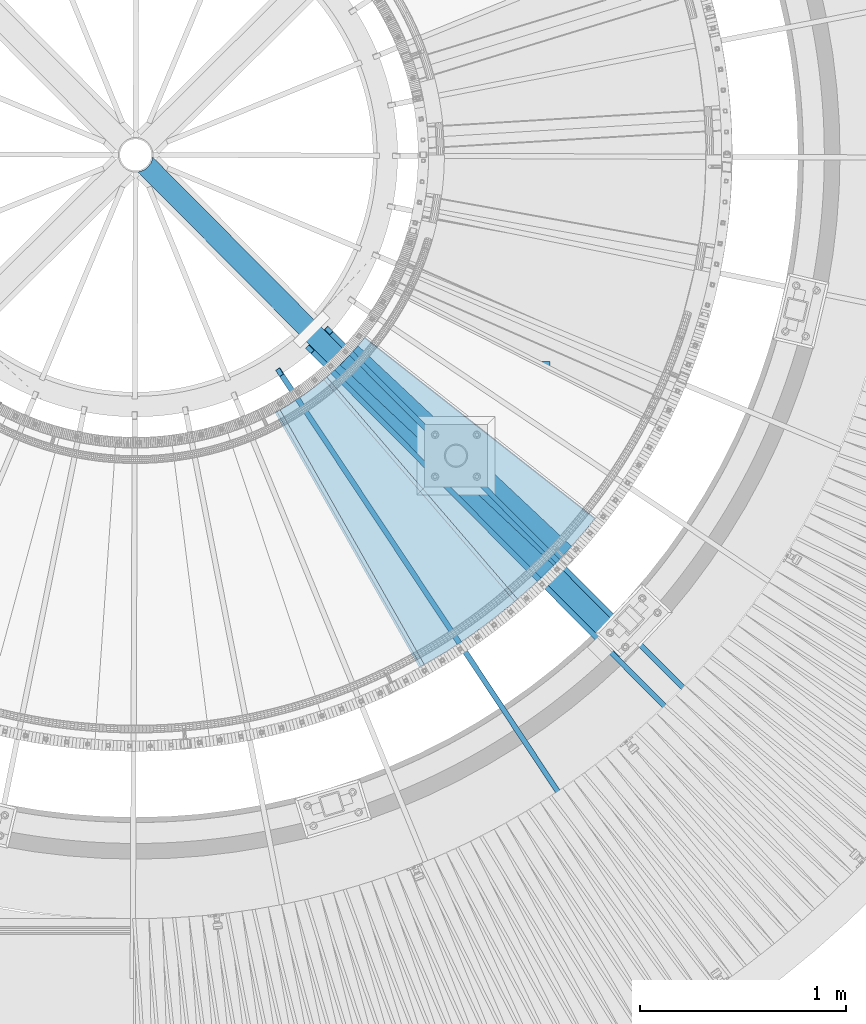
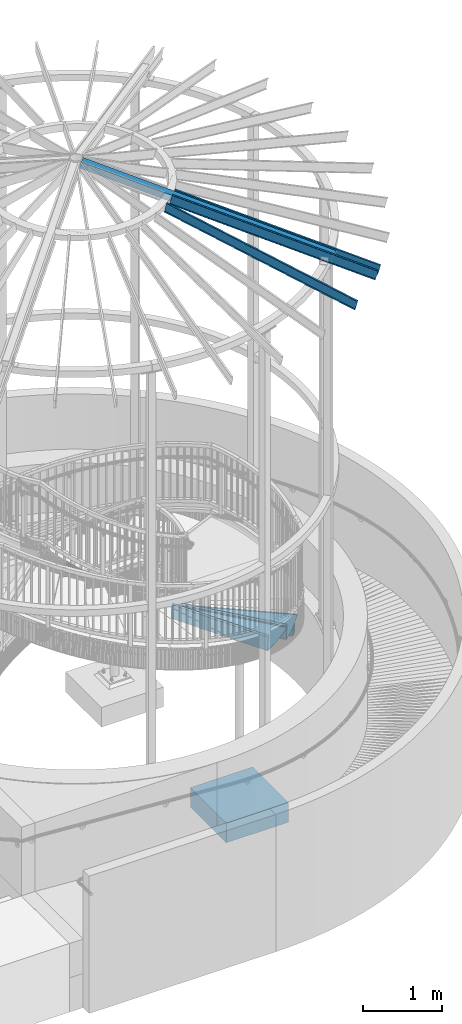
# One storey, part 357 of 975: 8 beams.
"""IFC2X3 building model written with IfcOpenShell, lengths in millimetres."""

from ifc_helpers import new_model, si_unit, frame, origin_with_axes, place, context, subcontext, project, spatial, faceted_brep, material, type_object, element, save


model = new_model("IFC2X3")

# Units and contexts
model_context = context("Model", 3, precision=1e-05, world=origin_with_axes())
body_context = subcontext(model_context, "Body", "Model", "MODEL_VIEW")
ifc_project = project(units=[si_unit("LENGTHUNIT", "METRE", prefix="MILLI"), si_unit("AREAUNIT", "SQUARE_METRE"), si_unit("VOLUMEUNIT", "CUBIC_METRE"), si_unit("MASSUNIT", "GRAM", prefix="KILO"), si_unit("TIMEUNIT", "SECOND"), si_unit("PLANEANGLEUNIT", "RADIAN"), si_unit("SOLIDANGLEUNIT", "STERADIAN"), si_unit("THERMODYNAMICTEMPERATUREUNIT", "DEGREE_CELSIUS"), si_unit("LUMINOUSINTENSITYUNIT", "LUMEN")], contexts=[model_context])

# Site, building, storey
site_placement = place(None, origin_with_axes())
site = spatial("IfcSite", under=ifc_project, at=site_placement, CompositionType="ELEMENT")
building_placement = place(site_placement, origin_with_axes())
building = spatial("IfcBuilding", under=site, at=building_placement, Name="Undefined", CompositionType="ELEMENT")
storey_placement = place(building_placement, origin_with_axes())
storey = spatial("IfcBuildingStorey", under=building, at=storey_placement, Name="Undefined", CompositionType="ELEMENT", Elevation=0.0)

# Beams
ifc_material_1 = material(Name="STEEL/A36")
beam_type_1 = type_object("IfcBeamType", PredefinedType="NOTDEFINED")
beam_1_placement = place(storey_placement, frame((36149.5064216353, 1731.87612086908, 2647.91695574218), z_axis=(0.651916463693756, -0.758290791428346, -5.11469806951936e-10), x_axis=(0.536192561053805, 0.460974552046187, 0.70710678107085)))
element("IfcBeam", 1, at=beam_1_placement, inside=storey, type_object=beam_type_1, material=ifc_material_1, Name="TREAD", context=body_context, shape_type="Brep", body=[
    faceted_brep([(25.4000001621371, 1.5874997143419, 653.28751700326), (1.61144271260127e-08, 1.58750000026703, 653.458911680114), (-1.96268956642598e-08, -1.58749999973588, 653.437487347819), (15.8745748038546, -1.5875001784334, 653.330368544412), (-120.373022221533, -103.76749224318, 653.560250726816), (-154.208562872085, -137.603032237963, 653.560249286144), (-49.0005534961238, -242.811041643061, 652.140399877677), (-46.7554894721361, -240.565977619684, 652.140399877557), (-149.718432901582, -137.603030988068, 653.529952160912), (-118.287540217565, -106.172138299769, 653.529952144057), (82.2634121742994, -374.075007349978, 638.193006315465), (84.508476198167, -371.829943326711, 638.193006315345), (212.601306559884, -504.412901568812, 612.134347567509), (214.846370562875, -502.167837565145, 612.134347570151), (261.055176792581, -530.596712595621, 601.111823144849), (259.197053542079, -528.103470062568, 601.754434690294), (248.701623596196, -536.023091227627, 602.134831213494), (248.362633442506, -540.174228440612, 601.571851715846), (250.921725105154, -538.24319290819, 601.479100122608), (25.4000001865188, 1.58749971376164, -768.618736200977), (-118.287540216395, -106.172138302336, -768.542582766611), (-149.718433278054, -137.603031368186, -768.542582749815), (-92.8426928760819, -194.478774201189, -768.783692225286), (-95.087756899542, -196.723838224048, -768.783692225159), (-154.208562871598, -137.603032235413, -768.533065523057), (-120.373022220361, -103.767492245748, -768.533065418116), (15.8745748282345, -1.58750017901184, -768.605275732323), (-1.58015609486029e-08, -1.58750000031432, -768.571627720263), (1.99397618416697e-08, 1.58749999968677, -768.564897939472), (-21.2434099455131, -266.078057151808, -776.330856581004), (-23.4884739689005, -268.323121174595, -776.330856580884), (49.7927349215133, -337.114201961485, -791.08236047571), (47.5476709198538, -339.35926596382, -791.082360478347), (66.437802308692, -335.979336534963, -793.502619428495), (56.3071310127107, -343.628597994977, -793.115412720523), (53.7487404151489, -345.560335457225, -793.01762786691), (54.0919957188744, -341.413461775162, -792.424099714608), (64.5845451579717, -333.490960101732, -792.825137753654)], [[[0, 1, 2, 3, 4, 5, 6, 7, 8, 9]], [[7, 6, 10, 11]], [[11, 10, 12, 13]], [[14, 15, 16, 13, 12, 17, 18]], [[19, 20, 21, 22, 23, 24, 25, 26, 27, 28]], [[29, 30, 23, 22]], [[31, 32, 30, 29]], [[33, 34, 35, 32, 31, 36, 37]], [[34, 33, 14, 18]], [[35, 34, 18, 17]], [[10, 6, 5, 24, 23, 30, 32, 35, 17, 12]], [[25, 24, 5, 4]], [[26, 25, 4, 3]], [[27, 26, 3, 2]], [[28, 27, 2, 1]], [[19, 28, 1, 0]], [[20, 19, 0, 9]], [[20, 9, 8, 21]], [[36, 31, 29, 22, 21, 8, 7, 11, 13, 16]], [[37, 36, 16, 15]], [[33, 37, 15, 14]]]),
])
beam_2_placement = place(storey_placement, frame((35799.0544908166, 1489.53948961688, 2825.71695574218), z_axis=(0.492761533846729, -0.87016439295171, -1.09573193185497e-10), x_axis=(0.615299143101833, 0.348435022057703, 0.707106781117108)))
element("IfcBeam", 2, at=beam_2_placement, inside=storey, type_object=beam_type_1, material=ifc_material_1, Name="TREAD", context=body_context, shape_type="Brep", body=[
    faceted_brep([(25.4000001621371, 1.5874997143419, 653.28751700326), (1.61144271260127e-08, 1.58750000026703, 653.458911680114), (-1.96268956642598e-08, -1.58749999973588, 653.437487347819), (15.8745748038546, -1.5875001784334, 653.330368544412), (-120.373022221533, -103.76749224318, 653.560250726816), (-154.208562872085, -137.603032237963, 653.560249286144), (-49.0005534961238, -242.811041643061, 652.140399877677), (-46.7554894721361, -240.565977619684, 652.140399877557), (-149.718432901582, -137.603030988068, 653.529952160912), (-118.287540217565, -106.172138299769, 653.529952144057), (82.2634121742994, -374.075007349978, 638.193006315465), (84.508476198167, -371.829943326711, 638.193006315345), (212.601306559884, -504.412901568812, 612.134347567509), (214.846370562875, -502.167837565145, 612.134347570151), (261.055176792581, -530.596712595621, 601.111823144849), (259.197053542079, -528.103470062568, 601.754434690294), (248.701623596196, -536.023091227627, 602.134831213494), (248.362633442506, -540.174228440612, 601.571851715846), (250.921725105154, -538.24319290819, 601.479100122608), (25.4000001865188, 1.58749971376164, -768.618736200977), (-118.287540216395, -106.172138302336, -768.542582766611), (-149.718433278054, -137.603031368186, -768.542582749815), (-92.8426928760819, -194.478774201189, -768.783692225286), (-95.087756899542, -196.723838224048, -768.783692225159), (-154.208562871598, -137.603032235413, -768.533065523057), (-120.373022220361, -103.767492245748, -768.533065418116), (15.8745748282345, -1.58750017901184, -768.605275732323), (-1.58015609486029e-08, -1.58750000031432, -768.571627720263), (1.99397618416697e-08, 1.58749999968677, -768.564897939472), (-21.2434099455131, -266.078057151808, -776.330856581004), (-23.4884739689005, -268.323121174595, -776.330856580884), (49.7927349215133, -337.114201961485, -791.08236047571), (47.5476709198538, -339.35926596382, -791.082360478347), (66.437802308692, -335.979336534963, -793.502619428495), (56.3071310127107, -343.628597994977, -793.115412720523), (53.7487404151489, -345.560335457225, -793.01762786691), (54.0919957188744, -341.413461775162, -792.424099714608), (64.5845451579717, -333.490960101732, -792.825137753654)], [[[0, 1, 2, 3, 4, 5, 6, 7, 8, 9]], [[7, 6, 10, 11]], [[11, 10, 12, 13]], [[14, 15, 16, 13, 12, 17, 18]], [[19, 20, 21, 22, 23, 24, 25, 26, 27, 28]], [[29, 30, 23, 22]], [[31, 32, 30, 29]], [[33, 34, 35, 32, 31, 36, 37]], [[34, 33, 14, 18]], [[35, 34, 18, 17]], [[10, 6, 5, 24, 23, 30, 32, 35, 17, 12]], [[25, 24, 5, 4]], [[26, 25, 4, 3]], [[27, 26, 3, 2]], [[28, 27, 2, 1]], [[19, 28, 1, 0]], [[20, 19, 0, 9]], [[20, 9, 8, 21]], [[36, 31, 29, 22, 21, 8, 7, 11, 13, 16]], [[37, 36, 16, 15]], [[33, 37, 15, 14]]]),
])
ifc_material_2 = material()
beam_type_2 = type_object("IfcBeamType", Name="HSS4X4X3/8", PredefinedType="NOTDEFINED")
beam_3_placement = place(storey_placement, frame((37133.4213526447, 987.034485133394, 8355.32707211838), z_axis=(0.170873527176511, -0.172130267177808, 0.970140922150774), x_axis=(-0.683475126987411, 0.688502112987316, 0.242541936995532)))
element("IfcBeam", 3, at=beam_3_placement, inside=storey, type_object=beam_type_2, material=ifc_material_2, Name="BEAM", ObjectType="HSS4X4X3/8", context=body_context, shape_type="Brep", body=[
    faceted_brep([(3438.83735812861, -22.0904176136246, 50.8000000013358), (3436.45604228348, -22.0904176085714, 41.2750000013289), (3433.41640701447, -0.308512534764304, 41.2750000013234), (3435.7977228596, -0.308512539817457, 50.8000000013285), (3436.29143033248, 21.4944170195777, 41.2750000013198), (3438.6727461776, 21.4944170145209, 50.8000000013249), (3454.30560025219, 50.8000000042775, 50.8000000013267), (3447.2664999947, 41.8325374313063, 50.8000000013249), (3421.8657976467, 41.8325374852029, -50.7999999987392), (3428.90489786185, 50.800000004263, -50.7999999987383), (3444.64959996888, 41.2750000042688, 41.275000001317), (3424.01152929259, 41.2750000042543, -41.274999998735), (3415.65335967472, 21.4944170633644, -41.2749999987323), (3413.27204382959, 21.4944170684175, -50.7999999987373), (3412.77833635671, -0.308512490973953, -41.2749999987295), (3410.39702051158, -0.308512485920801, -50.7999999987355), (3415.81797162572, -22.0904175647811, -41.2749999987223), (3413.43665578059, -22.0904175597279, -50.7999999987301), (3454.30536256338, -50.7999999956992, 50.8000000013449), (3428.90466025831, -50.7999999957137, -50.7999999987182), (3422.18380351628, -42.3668973185268, -50.7999999987219), (3447.58450586428, -42.3668973724198, 50.8000000013403), (3424.09408161953, -41.2749999957268, -41.2749999987177), (3444.7321522584, -41.2749999957123, 41.2750000013343), (6.3499999872256, 50.7999999999884, 50.8000000000225), (6.35000001109802, -50.799999999992, 50.8000000000425), (6.34999999362844, -50.7999999999738, -50.8000000000134), (6.34999996975966, 50.8000000000065, -50.8000000000334), (6.34999998782587, 41.2749999999942, 41.2750000000183), (6.35000000721993, -41.2749999999905, 41.2750000000347), (6.34999999302818, -41.274999999976, -41.2750000000101), (6.34999997363047, 41.2750000000087, -41.2750000000256)], [[[0, 1, 2, 3]], [[3, 2, 4, 5]], [[6, 7, 8, 9]], [[5, 4, 10, 11, 12, 13, 8, 7]], [[14, 15, 13, 12]], [[16, 17, 15, 14]], [[18, 19, 20, 21]], [[21, 20, 17, 16, 22, 23, 1, 0]], [[0, 3, 5, 7, 6, 24, 25, 18, 21]], [[26, 27, 9, 8, 13, 15, 17, 20, 19]], [[25, 26, 19, 18]], [[27, 24, 6, 9]], [[26, 25, 24, 27], [28, 29, 30, 31]], [[30, 29, 23, 22]], [[14, 12, 11, 31, 30, 22, 16]], [[28, 31, 11, 10]], [[29, 28, 10, 4, 2, 1, 23]]]),
])
beam_type_3 = type_object("IfcBeamType", Name="HSS5X5X3/8", PredefinedType="NOTDEFINED")
beam_4_placement = place(storey_placement, frame((35771.3611590921, 2429.58425853284, 2378.30794886957), z_axis=(0.0, 0.0, 1.0), x_axis=(0.728893036823587, -0.684627592834301, 0.0)))
element("IfcBeam", 4, at=beam_4_placement, inside=storey, type_object=beam_type_3, material=ifc_material_2, Name="BEAM", ObjectType="HSS5X5X3/8", context=body_context, shape_type="Brep", body=[
    faceted_brep([(1.30967237055302e-10, 53.9749999998749, -53.9749999999999), (-1.20053300634027e-10, -53.9749999998712, -53.9749999999999), (1424.77955062567, -53.9750000002823, -53.9749999999999), (1424.77955062555, 53.9749999996056, -53.9749999999999), (-1.20053300634027e-10, -53.9749999998712, 53.9749999999999), (1424.77955062567, -53.9750000002823, 53.9749999999999), (1.30967237055302e-10, 53.9749999998749, 53.9749999999999), (1424.77955062555, 53.9749999996056, 53.9749999999999), (1.56433088704944e-10, 63.4999999998508, -63.5), (1.56433088704944e-10, 63.4999999998508, 63.5), (1424.77955062554, 63.4999999995962, 63.5), (1424.77955062554, 63.4999999995962, -63.5), (-1.45519152283669e-10, -63.4999999998436, 63.5), (1424.77955062567, -63.5000000002801, 63.5), (-1.45519152283669e-10, -63.4999999998436, -63.5), (1424.77955062567, -63.5000000002801, -63.5)], [[[0, 1, 2, 3]], [[1, 4, 5, 2]], [[4, 6, 7, 5]], [[6, 0, 3, 7]], [[8, 9, 10, 11]], [[9, 12, 13, 10]], [[12, 14, 15, 13]], [[14, 8, 11, 15]], [[13, 15, 11, 10], [5, 7, 3, 2]], [[14, 12, 9, 8], [6, 4, 1, 0]]]),
])
ifc_material_3 = material(Name="STEEL/Zero_Density")
beam_type_4 = type_object("IfcBeamType", PredefinedType="NOTDEFINED")
for number, where, z_axis, x_axis, name in (
    (5, (35434.0677277533, 2348.90026319446, 8885.0313138005), (0.134009290222391, -0.202158604335487, 0.97014092214854), (0.536022339859084, -0.808612057787423, -0.242541936936238), "STUD"),
    (6, (35581.2548821243, 2460.57815678076, 8885.0313138005), (0.170873527176511, -0.172130267177808, 0.970140922150774), (0.683475207795134, -0.688502032793624, -0.242541936927299), "STUD"),
    (7, (37584.3750946901, 622.897378076747, 8206.16015010101), (0.170873527176511, -0.172130267177808, 0.970140922150774), (-0.683475126987411, 0.688502112987316, 0.242541936995532), "STUD"),
):
    element("IfcBeam", number, at=place(storey_placement, frame(where, z_axis=z_axis, x_axis=x_axis)), inside=storey, type_object=beam_type_4, material=ifc_material_3, Name=name, context=body_context, shape_type="Brep", body=[
        faceted_brep([(-1.67347025126219e-10, 12.6999999998588, -76.2000000000985), (1.96450855582952e-10, 12.7000000001644, 76.2000000001021), (2798.98467503002, 12.7000000041553, 76.2000000028588), (2798.98467502966, 12.7000000038533, -76.1999999973427), (1.74622982740402e-10, -12.6999999998661, 76.2000000000985), (2798.98467503, -12.6999999958753, 76.2000000028534), (1.67347025126219e-10, -12.6999999998698, 73.0250000000947), (2798.98467502999, -12.6999999958789, 73.0250000028504), (1.89174897968769e-10, 9.52500000015425, 73.0250000000974), (2798.98467503001, 9.52500000414511, 73.0250000028532), (-1.60071067512035e-10, 9.52499999986321, -73.0250000000938), (2798.98467502966, 9.52500000385407, -73.0249999973398), (-1.81898940354586e-10, -12.7000000001608, -73.0250000000965), (2798.98467502964, -12.6999999961699, -73.0249999973416), (-1.92812876775861e-10, -12.7000000001717, -76.2000000001003), (2798.98467502963, -12.6999999961772, -76.1999999973455)], [[[0, 1, 2, 3]], [[1, 4, 5, 2]], [[4, 6, 7, 5]], [[6, 8, 9, 7]], [[8, 10, 11, 9]], [[10, 12, 13, 11]], [[12, 14, 15, 13]], [[14, 0, 3, 15]], [[5, 7, 9, 11, 13, 15, 3, 2]], [[14, 12, 10, 8, 6, 4, 1, 0]]]),
    ])
ifc_material_4 = material(Name="CONCRETE/5000")
beam_type_5 = type_object("IfcBeamType", PredefinedType="NOTDEFINED")
beam_5_placement = place(storey_placement, frame((35832.4174033399, 1942.7404086606, -457.2), z_axis=(0.0, 0.0, 1.0), x_axis=(1.0, 0.0, 0.0)))
element("IfcBeam", 8, at=beam_5_placement, inside=storey, type_object=beam_type_5, material=ifc_material_4, Name="FOOTING", context=body_context, shape_type="Brep", body=[
    faceted_brep([(0.0, 457.2, -152.4), (0.0, 457.2, 152.4), (914.400000000001, 457.2, 152.4), (914.400000000001, 457.2, -152.4), (0.0, -457.2, 152.4), (914.400000000001, -457.2, 152.4), (0.0, -457.2, -152.4), (914.400000000001, -457.2, -152.4)], [[[0, 1, 2, 3]], [[1, 4, 5, 2]], [[4, 6, 7, 5]], [[6, 0, 3, 7]], [[5, 7, 3, 2]], [[6, 4, 1, 0]]]),
])

save(model, "model.ifc")
